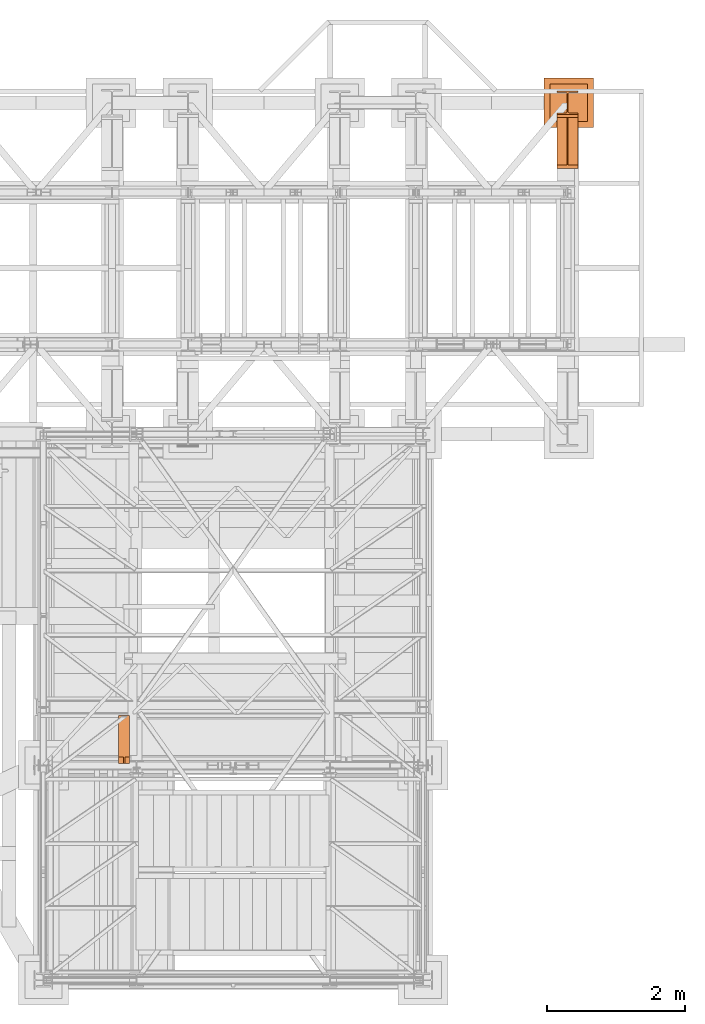
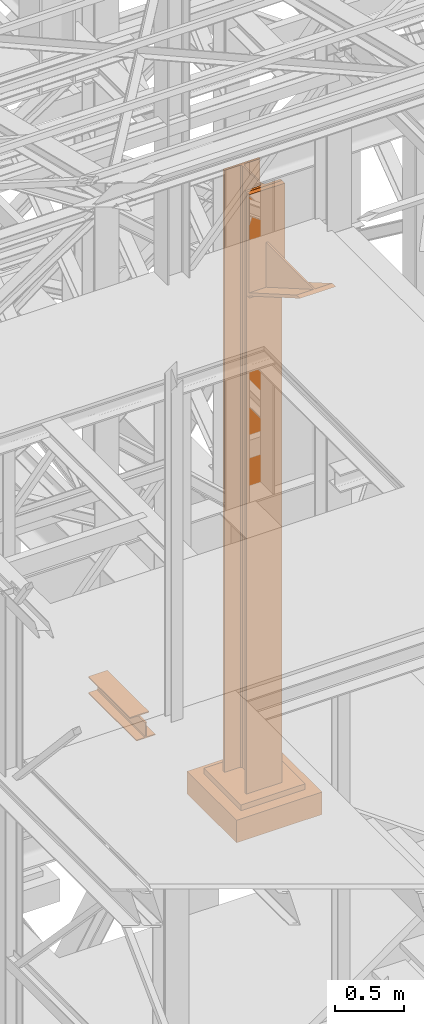
# One storey, part 200 of 208: 4 proxies.
"""IFC2X3 building model written with IfcOpenShell, lengths in millimetres."""

from ifc_helpers import new_model, entity, si_unit, converted_unit, frame, origin, origin_with_axes, place, context, subcontext, project, spatial, faceted_brep, material, element, save


model = new_model("IFC2X3")

# Units and contexts
model_context = context("Model", 3, precision=1e-05, world=origin())
plan_context = context("Plan", 3, precision=1e-05, world=origin())
body_context = subcontext(model_context, "Body", "Model", "MODEL_VIEW")
ifc_project = project(units=[si_unit("LENGTHUNIT", "METRE", prefix="MILLI"), converted_unit("PLANEANGLEUNIT", "DEGREE", entity("IfcPlaneAngleMeasure", 0.0174532925199433), si_unit("PLANEANGLEUNIT", "RADIAN"), dimensions=[0, 0, 0, 0, 0, 0, 0]), si_unit("AREAUNIT", "SQUARE_METRE"), si_unit("VOLUMEUNIT", "CUBIC_METRE")], contexts=[model_context, plan_context])

# Building, storey
building_placement = place(None, origin())
building = spatial("IfcBuilding", under=ifc_project, at=building_placement, CompositionType="COMPLEX")
storey_placement = place(building_placement, origin_with_axes())
storey = spatial("IfcBuildingStorey", under=building, at=storey_placement, Name="Geschoss", CompositionType="ELEMENT")

# Proxies
ifc_material = material(Name="35/80cm")
proxy_1_placement = place(storey_placement, frame((8643.254962568202, -12632.57439531566, -65.01000000000022), z_axis=(0.0, 0.0, 1.0), x_axis=(1.0, 0.0, 0.0)))
element("IfcBuildingElementProxy", 1, at=proxy_1_placement, inside=storey, material=ifc_material, context=body_context, shape_type="Brep", body=[
    faceted_brep([(300.0100119209292, 0.01000000000021828, 0.01000000000027512), (300.0100119209292, 21.51000631809256, 0.01000000000027512), (183.0100057816508, 21.51000631809256, 0.01000000000027512), (169.036290997863, 24.30682016372703, 0.01000000000027512), (158.8068282401564, 34.53628850936912, 0.01000000000027512), (156.0100060126188, 48.51000143051169, 0.01000000000027512), (156.0100060126188, 291.5099946951868, 0.01000000000027512), (158.8068282401564, 305.48371506691, 0.01000000000027512), (169.036290997863, 315.7131685113909, 0.01000000000027512), (183.0100057816508, 318.5099972581866, 0.01000000000027512), (300.0100119209292, 318.5099972581866, 0.01000000000027512), (300.0100119209292, 340.0100035762789, 0.01000000000027512), (0.01000000000021828, 340.0100035762789, 0.01000000000027512), (0.01000000000021828, 318.5099972581866, 0.01000000000027512), (117.0100061392786, 318.5099972581866, 0.01000000000027512), (130.9837209230664, 315.7131685113909, 0.01000000000027512), (141.213183680773, 305.48371506691, 0.01000000000027512), (144.0100059083106, 291.5099946951868, 0.01000000000027512), (144.0100059083106, 48.51000143051169, 0.01000000000027512), (141.213183680773, 34.53628850936912, 0.01000000000027512), (130.9837209230664, 24.30682016372703, 0.01000000000027512), (117.0100061392786, 21.51000631809256, 0.01000000000027512), (0.01000000000021828, 21.51000631809256, 0.01000000000027512), (0.01000000000021828, 0.01000000000021828, 0.01000000000027512), (300.0100119209292, 21.51000631809256, 5350.010005364416), (300.0100119209292, 0.01000000000021828, 5350.010005364416), (0.01000000000021828, 0.01000000000021828, 5350.010005364416), (0.01000000000021828, 21.51000631809256, 5350.010005364416), (117.0100061392786, 21.51000631809256, 5350.010005364416), (130.9837209230664, 24.30682016372703, 5350.010005364416), (141.213183680773, 34.53628850936912, 5350.010005364416), (144.0100059083106, 48.51000143051169, 5350.010005364416), (144.0100059083106, 291.5099946951868, 5350.010005364416), (141.213183680773, 305.48371506691, 5350.010005364416), (130.9837209230664, 315.7131685113909, 5350.010005364416), (117.0100061392786, 318.5099972581866, 5350.010005364416), (0.01000000000021828, 318.5099972581866, 5350.010005364416), (0.01000000000021828, 340.0100035762789, 5350.010005364416), (300.0100119209292, 340.0100035762789, 5350.010005364416), (300.0100119209292, 318.5099972581866, 5350.010005364416), (183.0100057816508, 318.5099972581866, 5350.010005364416), (169.036290997863, 315.7131685113909, 5350.010005364416), (158.8068282401564, 305.48371506691, 5350.010005364416), (156.0100060126188, 291.5099946951868, 5350.010005364416), (156.0100060126188, 48.51000143051169, 5350.010005364416), (158.8068282401564, 34.53628850936912, 5350.010005364416), (169.036290997863, 24.30682016372703, 5350.010005364416), (183.0100057816508, 21.51000631809256, 5350.010005364416), (300.0100119209292, 21.51000631809256, 0.01000000000027512), (300.0100119209292, 0.01000000000021828, 0.01000000000027512), (300.0100119209292, 0.01000000000021828, 5350.010005364416), (300.0100119209292, 21.51000631809256, 5350.010005364416), (183.0100057816508, 21.51000631809256, 0.01000000000027512), (300.0100119209292, 21.51000631809256, 0.01000000000027512), (300.0100119209292, 21.51000631809256, 5350.010005364416), (183.0100057816508, 21.51000631809256, 5350.010005364416), (169.036290997863, 24.30682016372703, 0.01000000000027512), (183.0100057816508, 21.51000631809256, 0.01000000000027512), (183.0100057816508, 21.51000631809256, 5350.010005364416), (169.036290997863, 24.30682016372703, 5350.010005364416), (158.8068282401564, 34.53628850936912, 0.01000000000027512), (169.036290997863, 24.30682016372703, 0.01000000000027512), (169.036290997863, 24.30682016372703, 5350.010005364416), (158.8068282401564, 34.53628850936912, 5350.010005364416), (156.0100060126188, 48.51000143051169, 0.01000000000027512), (158.8068282401564, 34.53628850936912, 0.01000000000027512), (158.8068282401564, 34.53628850936912, 5350.010005364416), (156.0100060126188, 48.51000143051169, 5350.010005364416), (156.0100060126188, 291.5099946951868, 0.01000000000027512), (156.0100060126188, 48.51000143051169, 0.01000000000027512), (156.0100060126188, 48.51000143051169, 5350.010005364416), (156.0100060126188, 291.5099946951868, 5350.010005364416), (158.8068282401564, 305.48371506691, 0.01000000000027512), (156.0100060126188, 291.5099946951868, 0.01000000000027512), (156.0100060126188, 291.5099946951868, 5350.010005364416), (158.8068282401564, 305.48371506691, 5350.010005364416), (169.036290997863, 315.7131685113909, 0.01000000000027512), (158.8068282401564, 305.48371506691, 0.01000000000027512), (158.8068282401564, 305.48371506691, 5350.010005364416), (169.036290997863, 315.7131685113909, 5350.010005364416), (183.0100057816508, 318.5099972581866, 0.01000000000027512), (169.036290997863, 315.7131685113909, 0.01000000000027512), (169.036290997863, 315.7131685113909, 5350.010005364416), (183.0100057816508, 318.5099972581866, 5350.010005364416), (300.0100119209292, 318.5099972581866, 0.01000000000027512), (183.0100057816508, 318.5099972581866, 0.01000000000027512), (183.0100057816508, 318.5099972581866, 5350.010005364416), (300.0100119209292, 318.5099972581866, 5350.010005364416), (300.0100119209292, 340.0100035762789, 0.01000000000027512), (300.0100119209292, 318.5099972581866, 0.01000000000027512), (300.0100119209292, 318.5099972581866, 5350.010005364416), (300.0100119209292, 340.0100035762789, 5350.010005364416), (0.01000000000021828, 340.0100035762789, 0.01000000000027512), (300.0100119209292, 340.0100035762789, 0.01000000000027512), (300.0100119209292, 340.0100035762789, 5350.010005364416), (0.01000000000021828, 340.0100035762789, 5350.010005364416), (0.01000000000021828, 318.5099972581866, 0.01000000000027512), (0.01000000000021828, 340.0100035762789, 0.01000000000027512), (0.01000000000021828, 340.0100035762789, 5350.010005364416), (0.01000000000021828, 318.5099972581866, 5350.010005364416), (117.0100061392786, 318.5099972581866, 0.01000000000027512), (0.01000000000021828, 318.5099972581866, 0.01000000000027512), (0.01000000000021828, 318.5099972581866, 5350.010005364416), (117.0100061392786, 318.5099972581866, 5350.010005364416), (130.9837209230664, 315.7131685113909, 0.01000000000027512), (117.0100061392786, 318.5099972581866, 0.01000000000027512), (117.0100061392786, 318.5099972581866, 5350.010005364416), (130.9837209230664, 315.7131685113909, 5350.010005364416), (141.213183680773, 305.48371506691, 0.01000000000027512), (130.9837209230664, 315.7131685113909, 0.01000000000027512), (130.9837209230664, 315.7131685113909, 5350.010005364416), (141.213183680773, 305.48371506691, 5350.010005364416), (144.0100059083106, 291.5099946951868, 0.01000000000027512), (141.213183680773, 305.48371506691, 0.01000000000027512), (141.213183680773, 305.48371506691, 5350.010005364416), (144.0100059083106, 291.5099946951868, 5350.010005364416), (144.0100059083106, 48.51000143051169, 0.01000000000027512), (144.0100059083106, 291.5099946951868, 0.01000000000027512), (144.0100059083106, 291.5099946951868, 5350.010005364416), (144.0100059083106, 48.51000143051169, 5350.010005364416), (141.213183680773, 34.53628850936912, 0.01000000000027512), (144.0100059083106, 48.51000143051169, 0.01000000000027512), (144.0100059083106, 48.51000143051169, 5350.010005364416), (141.213183680773, 34.53628850936912, 5350.010005364416), (130.9837209230664, 24.30682016372703, 0.01000000000027512), (141.213183680773, 34.53628850936912, 0.01000000000027512), (141.213183680773, 34.53628850936912, 5350.010005364416), (130.9837209230664, 24.30682016372703, 5350.010005364416), (117.0100061392786, 21.51000631809256, 0.01000000000027512), (130.9837209230664, 24.30682016372703, 0.01000000000027512), (130.9837209230664, 24.30682016372703, 5350.010005364416), (117.0100061392786, 21.51000631809256, 5350.010005364416), (0.01000000000021828, 21.51000631809256, 0.01000000000027512), (117.0100061392786, 21.51000631809256, 0.01000000000027512), (117.0100061392786, 21.51000631809256, 5350.010005364416), (0.01000000000021828, 21.51000631809256, 5350.010005364416), (0.01000000000021828, 0.01000000000021828, 0.01000000000027512), (0.01000000000021828, 21.51000631809256, 0.01000000000027512), (0.01000000000021828, 21.51000631809256, 5350.010005364416), (0.01000000000021828, 0.01000000000021828, 5350.010005364416), (300.0100119209292, 0.01000000000021828, 0.01000000000027512), (0.01000000000021828, 0.01000000000021828, 0.01000000000027512), (0.01000000000021828, 0.01000000000021828, 5350.010005364416), (300.0100119209292, 0.01000000000021828, 5350.010005364416)], [[[0, 1, 2, 3, 4, 5, 6, 7, 8, 9, 10, 11, 12, 13, 14, 15, 16, 17, 18, 19, 20, 21, 22, 23]], [[24, 25, 26, 27, 28, 29, 30, 31, 32, 33, 34, 35, 36, 37, 38, 39, 40, 41, 42, 43, 44, 45, 46, 47]], [[48, 49, 50, 51]], [[52, 53, 54, 55]], [[56, 57, 58, 59]], [[60, 61, 62, 63]], [[64, 65, 66, 67]], [[68, 69, 70, 71]], [[72, 73, 74, 75]], [[76, 77, 78, 79]], [[80, 81, 82, 83]], [[84, 85, 86, 87]], [[88, 89, 90, 91]], [[92, 93, 94, 95]], [[96, 97, 98, 99]], [[100, 101, 102, 103]], [[104, 105, 106, 107]], [[108, 109, 110, 111]], [[112, 113, 114, 115]], [[116, 117, 118, 119]], [[120, 121, 122, 123]], [[124, 125, 126, 127]], [[128, 129, 130, 131]], [[132, 133, 134, 135]], [[136, 137, 138, 139]], [[140, 141, 142, 143]]], orient=[[False], [False], [False], [False], [False], [False], [False], [False], [False], [False], [False], [False], [False], [False], [False], [False], [False], [False], [False], [False], [False], [False], [False], [False], [False], [False]]),
])
proxy_2_placement = place(storey_placement, frame((8643.254974489131, -13412.43639531566, 4367.230005364415), z_axis=(0.0, 0.0, 1.0), x_axis=(1.0, 0.0, 0.0)))
element("IfcBuildingElementProxy", 2, at=proxy_2_placement, inside=storey, context=body_context, shape_type="Brep", body=[
    faceted_brep([(0.01000000000021828, 739.8719999999994, 18.61000000000058), (0.01000000000021828, 0.01000000000021828, 445.7700000000004), (300.0100000000002, 0.01000000000021828, 445.7700000000004), (300.0100000000002, 739.8719999999994, 18.61000000000058), (0.01000000000021828, 0.01000000000021828, 445.7700000000004), (0.01000000000021828, 50.06600000000071, 445.7710000000006), (142.5100000000002, 50.06600000000071, 445.7710000000006), (142.5100000000002, 739.8719999999994, 445.7700000000004), (157.5100000000002, 739.8719999999994, 445.7700000000004), (157.5100000000002, 50.06600000000071, 445.7710000000006), (300.0100000000002, 50.06600000000071, 445.7710000000006), (300.0100000000002, 0.01000000000021828, 445.7700000000004), (0.01000000000021828, 50.06600000000071, 445.7710000000006), (0.01000000000021828, 739.8719999999994, 47.51000000000022), (142.5100000000002, 739.8719999999994, 47.51000000000022), (142.5100000000002, 50.06600000000071, 445.7710000000006), (157.5100000000002, 739.8719999999994, 47.51000000000022), (300.0100000000002, 739.8719999999994, 47.51000000000022), (300.0100000000002, 50.06600000000071, 445.7710000000006), (157.5100000000002, 50.06600000000071, 445.7710000000006), (0.01000000000021828, 739.8719999999994, 18.61000000000058), (0.01000000000021828, 739.8719999999994, 0.01000000000021828), (0.01000000000021828, 779.8719999999994, 0.01000000000021828), (0.01000000000021828, 779.8719999999994, 917.7700000000013), (0.01000000000021828, 739.8719999999994, 917.7700000000013), (0.01000000000021828, 739.8719999999994, 47.51000000000022), (0.01000000000021828, 50.06600000000071, 445.7710000000006), (0.01000000000021828, 0.01000000000021828, 445.7700000000004), (300.0100000000002, 779.8720000000012, 917.7700000000013), (300.0100000000002, 779.8719999999994, 0.01000000000021828), (300.0100000000002, 739.8719999999994, 0.01000000000021828), (300.0100000000002, 739.8719999999994, 18.61000000000058), (300.0100000000002, 0.01000000000021828, 445.7700000000004), (300.0100000000002, 50.06600000000071, 445.7710000000006), (300.0100000000002, 739.8719999999994, 47.51000000000022), (300.0100000000002, 739.8720000000012, 917.7700000000013), (300.0100000000002, 779.8720000000012, 917.7700000000013), (300.0100000000002, 739.8720000000012, 917.7700000000013), (0.01000000000021828, 739.8719999999994, 917.7700000000013), (0.01000000000021828, 779.8719999999994, 917.7700000000013), (300.0100000000002, 739.8720000000012, 917.7700000000013), (300.0100000000002, 739.8719999999994, 47.51000000000022), (157.5100000000002, 739.8719999999994, 47.51000000000022), (157.5100000000002, 739.8719999999994, 445.7700000000004), (142.5100000000002, 739.8719999999994, 445.7700000000004), (142.5100000000002, 739.8719999999994, 47.51000000000022), (0.01000000000021828, 739.8719999999994, 47.51000000000022), (0.01000000000021828, 739.8719999999994, 917.7700000000013), (300.0100000000002, 739.8719999999994, 18.61000000000058), (300.0100000000002, 739.8719999999994, 0.01000000000021828), (0.01000000000021828, 739.8719999999994, 0.01000000000021828), (0.01000000000021828, 739.8719999999994, 18.61000000000058), (300.0100000000002, 739.8719999999994, 0.01000000000021828), (300.0100000000002, 779.8719999999994, 0.01000000000021828), (0.01000000000021828, 779.8719999999994, 0.01000000000021828), (0.01000000000021828, 739.8719999999994, 0.01000000000021828), (300.0100000000002, 779.8719999999994, 0.01000000000021828), (300.0100000000002, 779.8720000000012, 917.7700000000013), (0.01000000000021828, 779.8719999999994, 917.7700000000013), (0.01000000000021828, 779.8719999999994, 0.01000000000021828), (142.5100000000002, 739.8719999999994, 47.51000000000022), (142.5100000000002, 739.8719999999994, 445.7700000000004), (142.5100000000002, 50.06600000000071, 445.7710000000006), (157.5100000000002, 739.8719999999994, 47.51000000000022), (157.5100000000002, 50.06600000000071, 445.7710000000006), (157.5100000000002, 739.8719999999994, 445.7700000000004)], [[[0, 1, 2, 3]], [[4, 5, 6, 7, 8, 9, 10, 11]], [[12, 13, 14, 15]], [[16, 17, 18, 19]], [[20, 21, 22, 23, 24, 25, 26, 27]], [[28, 29, 30, 31, 32, 33, 34, 35]], [[36, 37, 38, 39]], [[40, 41, 42, 43, 44, 45, 46, 47]], [[48, 49, 50, 51]], [[52, 53, 54, 55]], [[56, 57, 58, 59]], [[60, 61, 62]], [[63, 64, 65]]], orient=[[False], [False], [False], [False], [False], [False], [False], [False], [False], [False], [False], [False], [False]]),
])
proxy_3_placement = place(storey_placement, frame((8449.779705904713, -12822.57439725281, -315.0099999999999), z_axis=(0.0, 0.0, 1.0), x_axis=(1.0, 0.0, 0.0)))
element("IfcBuildingElementProxy", 3, at=proxy_3_placement, inside=storey, context=body_context, shape_type="Brep", body=[
    faceted_brep([(630.0100000000002, 630.0100000000002, 250.01), (630.0100000000002, 90.01000000000022, 250.01), (90.01000000000022, 90.01000000000022, 250.01), (90.01000000000022, 630.0100000000002, 250.01), (630.0100000000002, 630.0100000000002, 200.01), (630.0100000000002, 90.01000000000022, 200.01), (630.0100000000002, 90.01000000000022, 250.01), (630.0100000000002, 630.0100000000002, 250.01), (90.01000000000022, 630.0100000000002, 200.01), (630.0100000000002, 630.0100000000002, 200.01), (630.0100000000002, 630.0100000000002, 250.01), (90.01000000000022, 630.0100000000002, 250.01), (90.01000000000022, 90.01000000000022, 200.01), (90.01000000000022, 630.0100000000002, 200.01), (90.01000000000022, 630.0100000000002, 250.01), (90.01000000000022, 90.01000000000022, 250.01), (630.0100000000002, 90.01000000000022, 200.01), (90.01000000000022, 90.01000000000022, 200.01), (90.01000000000022, 90.01000000000022, 250.01), (630.0100000000002, 90.01000000000022, 250.01), (720.0100000000002, 0.01000000000021828, 0.009999999999990905), (720.0100000000002, 720.0100000000002, 0.009999999999990905), (0.01000000000021828, 720.0100000000002, 0.009999999999990905), (0.01000000000021828, 0.01000000000021828, 0.009999999999990905), (720.0100000000002, 720.0100000000002, 200.01), (720.0100000000002, 0.01000000000021828, 200.01), (0.01000000000021828, 0.01000000000021828, 200.01), (0.01000000000021828, 720.0100000000002, 200.01), (90.01000000000022, 90.01000000000022, 200.01), (630.0100000000002, 90.01000000000022, 200.01), (630.0100000000002, 630.0100000000002, 200.01), (90.01000000000022, 630.0100000000002, 200.01), (720.0100000000002, 720.0100000000002, 0.009999999999990905), (720.0100000000002, 0.01000000000021828, 0.009999999999990905), (720.0100000000002, 0.01000000000021828, 200.01), (720.0100000000002, 720.0100000000002, 200.01), (0.01000000000021828, 720.0100000000002, 0.009999999999990905), (720.0100000000002, 720.0100000000002, 0.009999999999990905), (720.0100000000002, 720.0100000000002, 200.01), (0.01000000000021828, 720.0100000000002, 200.01), (0.01000000000021828, 0.01000000000021828, 0.009999999999990905), (0.01000000000021828, 720.0100000000002, 0.009999999999990905), (0.01000000000021828, 720.0100000000002, 200.01), (0.01000000000021828, 0.01000000000021828, 200.01), (720.0100000000002, 0.01000000000021828, 0.009999999999990905), (0.01000000000021828, 0.01000000000021828, 0.009999999999990905), (0.01000000000021828, 0.01000000000021828, 200.01), (720.0100000000002, 0.01000000000021828, 200.01)], [[[0, 1, 2, 3]], [[4, 5, 6, 7]], [[8, 9, 10, 11]], [[12, 13, 14, 15]], [[16, 17, 18, 19]], [[20, 21, 22, 23]], [[24, 25, 26, 27], [28, 29, 30, 31]], [[32, 33, 34, 35]], [[36, 37, 38, 39]], [[40, 41, 42, 43]], [[44, 45, 46, 47]]], orient=[[False], [False], [False], [False], [False], [False], [False, False], [False], [False], [False], [False]]),
])
proxy_4_placement = place(storey_placement, frame((2288.254962866221, -22037.82438858936, 8332.989992072577), z_axis=(0.0, 0.0, 1.0), x_axis=(1.0, 0.0, 0.0)))
element("IfcBuildingElementProxy", 4, at=proxy_4_placement, inside=storey, context=body_context, shape_type="Brep", body=[
    faceted_brep([(160.0100113248827, 700.2599935030994, 152.0100100135805), (160.0100113248845, 95.26000303984256, 152.0100100135805), (0.01000000000294676, 95.26000303984256, 152.0100100135805), (0.01000000000021828, 700.2599935030994, 152.0100100135805), (0.01000000000021828, 700.2599935030994, 152.0100100135805), (0.01000000000294676, 95.26000303984256, 152.0100100135805), (0.01000000000294676, 95.26000303984256, 143.0100066757204), (0.01000000000112777, 700.2599935030994, 143.0100066757204), (0.01000000000112777, 700.2599935030994, 143.0100066757204), (0.01000000000294676, 95.26000303984256, 143.0100066757204), (62.01000457465852, 95.26000303984256, 143.0100066757204), (62.01000457465671, 700.2599935030994, 143.0100066757204), (62.01000457465671, 700.2599935030994, 143.0100066757204), (62.01000457465852, 95.26000303984256, 143.0100066757204), (69.77318079978522, 95.26000303984256, 141.4562178945544), (69.7731807997834, 700.2599935030994, 141.4562178945544), (69.7731807997834, 700.2599935030994, 141.4562178945544), (69.77318079978522, 95.26000303984256, 141.4562178945544), (71.21939064771232, 95.26000303984256, 140.0100080466273), (71.21939064771232, 0.00999999999839929, 140.0100080466273), (75.45621545821723, 0.00999999999839929, 135.7731832361224), (75.45621545821541, 700.2599935030994, 135.7731832361224), (75.45621545821541, 700.2599935030994, 135.7731832361224), (75.45621545821723, 0.00999999999839929, 135.7731832361224), (77.01000563636717, 0.00999999999839929, 128.0100098049643), (77.01000563636535, 700.2599935030994, 128.0100098049643), (77.01000563636535, 700.2599935030994, 128.0100098049643), (77.01000563636717, 0.00999999999839929, 128.0100098049643), (77.01000563636717, 0.00999999999839929, 24.01000393390677), (77.01000563636535, 700.2599935030994, 24.01000393390677), (77.01000563636535, 700.2599935030994, 24.01000393390677), (77.01000563636717, 0.00999999999839929, 24.01000393390677), (75.45621545821723, 0.00999999999839929, 16.24682677745841), (75.4562154582145, 700.2599935030994, 16.24682677745841), (75.4562154582145, 700.2599935030994, 16.24682677745841), (75.45621545821723, 0.00999999999839929, 16.24682677745841), (69.77318079978522, 0.00999999999839929, 10.5637921190264), (69.7731807997834, 700.2599935030994, 10.5637921190264), (69.7731807997834, 700.2599935030994, 10.5637921190264), (69.77318079978522, 0.00999999999839929, 10.5637921190264), (62.01000457465943, 0.00999999999839929, 9.010003337860326), (62.01000457465761, 700.2599935030994, 9.010003337860326), (62.01000457465761, 700.2599935030994, 9.010003337860326), (62.01000457465943, 0.00999999999839929, 9.010003337860326), (0.01000000000294676, 0.00999999999839929, 9.010003337860326), (0.01000000000112777, 700.2599935030994, 9.010003337860326), (0.01000000000112777, 700.2599935030994, 9.010003337860326), (0.01000000000294676, 0.00999999999839929, 9.010003337860326), (0.01000000000294676, 0.00999999999839929, 0.01000000000021828), (0.01000000000112777, 700.2599935030994, 0.01000000000021828), (0.01000000000112777, 700.2599935030994, 0.01000000000021828), (0.01000000000294676, 0.00999999999839929, 0.01000000000021828), (160.0100113248855, 0.00999999999839929, 0.01000000000021828), (160.0100113248827, 700.2599935030994, 0.01000000000021828), (160.0100113248827, 700.2599935030994, 0.01000000000021828), (160.0100113248855, 0.00999999999839929, 0.01000000000021828), (160.0100113248855, 0.00999999999839929, 9.010003337860326), (160.0100113248827, 700.2599935030994, 9.010003337860326), (160.0100113248827, 700.2599935030994, 9.010003337860326), (160.0100113248855, 0.00999999999839929, 9.010003337860326), (98.01000675022897, 0.00999999999839929, 9.010003337860326), (98.01000675022624, 700.2599935030994, 9.010003337860326), (98.01000675022624, 700.2599935030994, 9.010003337860326), (98.01000675022897, 0.00999999999839929, 9.010003337860326), (90.24683052510318, 0.00999999999839929, 10.5637921190264), (90.24683052510045, 700.2599935030994, 10.5637921190264), (90.24683052510045, 700.2599935030994, 10.5637921190264), (90.24683052510318, 0.00999999999839929, 10.5637921190264), (84.56379586667117, 0.00999999999839929, 16.24682677745841), (84.56379586666935, 700.2599935030994, 16.24682677745841), (84.56379586666935, 700.2599935030994, 16.24682677745841), (84.56379586667117, 0.00999999999839929, 16.24682677745841), (83.01000568852123, 0.00999999999839929, 24.01000393390677), (83.0100056885185, 700.2599935030994, 24.01000393390677), (83.0100056885185, 700.2599935030994, 24.01000393390677), (83.01000568852123, 0.00999999999839929, 24.01000393390677), (83.01000568852123, 0.00999999999839929, 128.0100098049643), (83.01000568851941, 700.2599935030994, 128.0100098049643), (83.01000568851941, 700.2599935030994, 128.0100098049643), (83.01000568852123, 0.00999999999839929, 128.0100098049643), (84.56379586667117, 0.00999999999839929, 135.7731832361224), (84.56379586666844, 700.2599935030994, 135.7731832361224), (84.56379586666844, 700.2599935030994, 135.7731832361224), (84.56379586667117, 0.00999999999839929, 135.7731832361224), (88.80062067717608, 0.00999999999839929, 140.0100080466273), (88.800620677177, 95.26000303984256, 140.0100080466273), (90.24683052510227, 95.26000303984256, 141.4562178945544), (90.24683052510136, 700.2599935030994, 141.4562178945544), (90.24683052510136, 700.2599935030994, 141.4562178945544), (90.24683052510227, 95.26000303984256, 141.4562178945544), (98.01000675022897, 95.26000303984256, 143.0100066757204), (98.01000675022624, 700.2599935030994, 143.0100066757204), (98.01000675022624, 700.2599935030994, 143.0100066757204), (98.01000675022897, 95.26000303984256, 143.0100066757204), (160.0100113248845, 95.26000303984256, 143.0100066757204), (160.0100113248827, 700.2599935030994, 143.0100066757204), (160.0100113248827, 700.2599935030994, 143.0100066757204), (160.0100113248845, 95.26000303984256, 143.0100066757204), (160.0100113248845, 95.26000303984256, 152.0100100135805), (160.0100113248827, 700.2599935030994, 152.0100100135805), (88.80062067717608, 0.00999999999839929, 140.0100080466273), (84.56379586667117, 0.00999999999839929, 135.7731832361224), (83.01000568852123, 0.00999999999839929, 128.0100098049643), (83.01000568852123, 0.00999999999839929, 24.01000393390677), (84.56379586667117, 0.00999999999839929, 16.24682677745841), (90.24683052510318, 0.00999999999839929, 10.5637921190264), (98.01000675022897, 0.00999999999839929, 9.010003337860326), (160.0100113248855, 0.00999999999839929, 9.010003337860326), (160.0100113248855, 0.00999999999839929, 0.01000000000021828), (0.01000000000294676, 0.00999999999839929, 0.01000000000021828), (0.01000000000294676, 0.00999999999839929, 9.010003337860326), (62.01000457465943, 0.00999999999839929, 9.010003337860326), (69.77318079978522, 0.00999999999839929, 10.5637921190264), (75.45621545821723, 0.00999999999839929, 16.24682677745841), (77.01000563636717, 0.00999999999839929, 24.01000393390677), (77.01000563636717, 0.00999999999839929, 128.0100098049643), (75.45621545821723, 0.00999999999839929, 135.7731832361224), (71.21939064771232, 0.00999999999839929, 140.0100080466273), (160.0100113248845, 95.26000303984256, 152.0100100135805), (160.0100113248845, 95.26000303984256, 143.0100066757204), (98.01000675022897, 95.26000303984256, 143.0100066757204), (90.24683052510227, 95.26000303984256, 141.4562178945544), (88.800620677177, 95.26000303984256, 140.0100080466273), (71.21939064771232, 95.26000303984256, 140.0100080466273), (69.77318079978522, 95.26000303984256, 141.4562178945544), (62.01000457465852, 95.26000303984256, 143.0100066757204), (0.01000000000294676, 95.26000303984256, 143.0100066757204), (0.01000000000294676, 95.26000303984256, 152.0100100135805), (88.800620677177, 95.26000303984256, 140.0100080466273), (88.80062067717608, 0.00999999999839929, 140.0100080466273), (71.21939064771232, 0.00999999999839929, 140.0100080466273), (71.21939064771232, 95.26000303984256, 140.0100080466273), (0.01000000000021828, 700.2599935030994, 152.0100100135805), (0.01000000000112777, 700.2599935030994, 143.0100066757204), (62.01000457465671, 700.2599935030994, 143.0100066757204), (69.7731807997834, 700.2599935030994, 141.4562178945544), (75.45621545821541, 700.2599935030994, 135.7731832361224), (77.01000563636535, 700.2599935030994, 128.0100098049643), (77.01000563636535, 700.2599935030994, 24.01000393390677), (75.4562154582145, 700.2599935030994, 16.24682677745841), (69.7731807997834, 700.2599935030994, 10.5637921190264), (62.01000457465761, 700.2599935030994, 9.010003337860326), (0.01000000000112777, 700.2599935030994, 9.010003337860326), (0.01000000000112777, 700.2599935030994, 0.01000000000021828), (160.0100113248827, 700.2599935030994, 0.01000000000021828), (160.0100113248827, 700.2599935030994, 9.010003337860326), (98.01000675022624, 700.2599935030994, 9.010003337860326), (90.24683052510045, 700.2599935030994, 10.5637921190264), (84.56379586666935, 700.2599935030994, 16.24682677745841), (83.0100056885185, 700.2599935030994, 24.01000393390677), (83.01000568851941, 700.2599935030994, 128.0100098049643), (84.56379586666844, 700.2599935030994, 135.7731832361224), (90.24683052510136, 700.2599935030994, 141.4562178945544), (98.01000675022624, 700.2599935030994, 143.0100066757204), (160.0100113248827, 700.2599935030994, 143.0100066757204), (160.0100113248827, 700.2599935030994, 152.0100100135805)], [[[0, 1, 2, 3]], [[4, 5, 6, 7]], [[8, 9, 10, 11]], [[12, 13, 14, 15]], [[16, 17, 18, 19, 20, 21]], [[22, 23, 24, 25]], [[26, 27, 28, 29]], [[30, 31, 32, 33]], [[34, 35, 36, 37]], [[38, 39, 40, 41]], [[42, 43, 44, 45]], [[46, 47, 48, 49]], [[50, 51, 52, 53]], [[54, 55, 56, 57]], [[58, 59, 60, 61]], [[62, 63, 64, 65]], [[66, 67, 68, 69]], [[70, 71, 72, 73]], [[74, 75, 76, 77]], [[78, 79, 80, 81]], [[82, 83, 84, 85, 86, 87]], [[88, 89, 90, 91]], [[92, 93, 94, 95]], [[96, 97, 98, 99]], [[100, 101, 102, 103, 104, 105, 106, 107, 108, 109, 110, 111, 112, 113, 114, 115, 116, 117]], [[118, 119, 120, 121, 122, 123, 124, 125, 126, 127]], [[128, 129, 130, 131]], [[132, 133, 134, 135, 136, 137, 138, 139, 140, 141, 142, 143, 144, 145, 146, 147, 148, 149, 150, 151, 152, 153, 154, 155]]], orient=[[False], [False], [False], [False], [False], [False], [False], [False], [False], [False], [False], [False], [False], [False], [False], [False], [False], [False], [False], [False], [False], [False], [False], [False], [False], [False], [False], [False]]),
])

save(model, "model.ifc")
